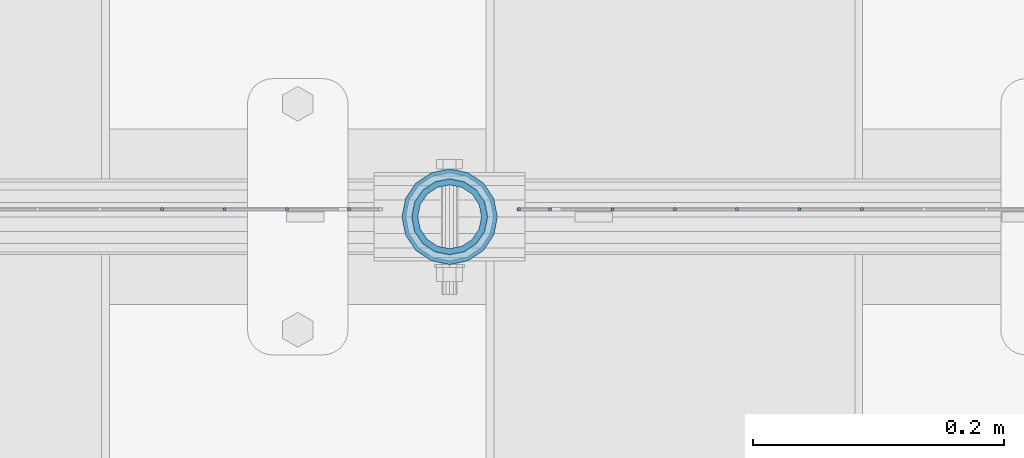
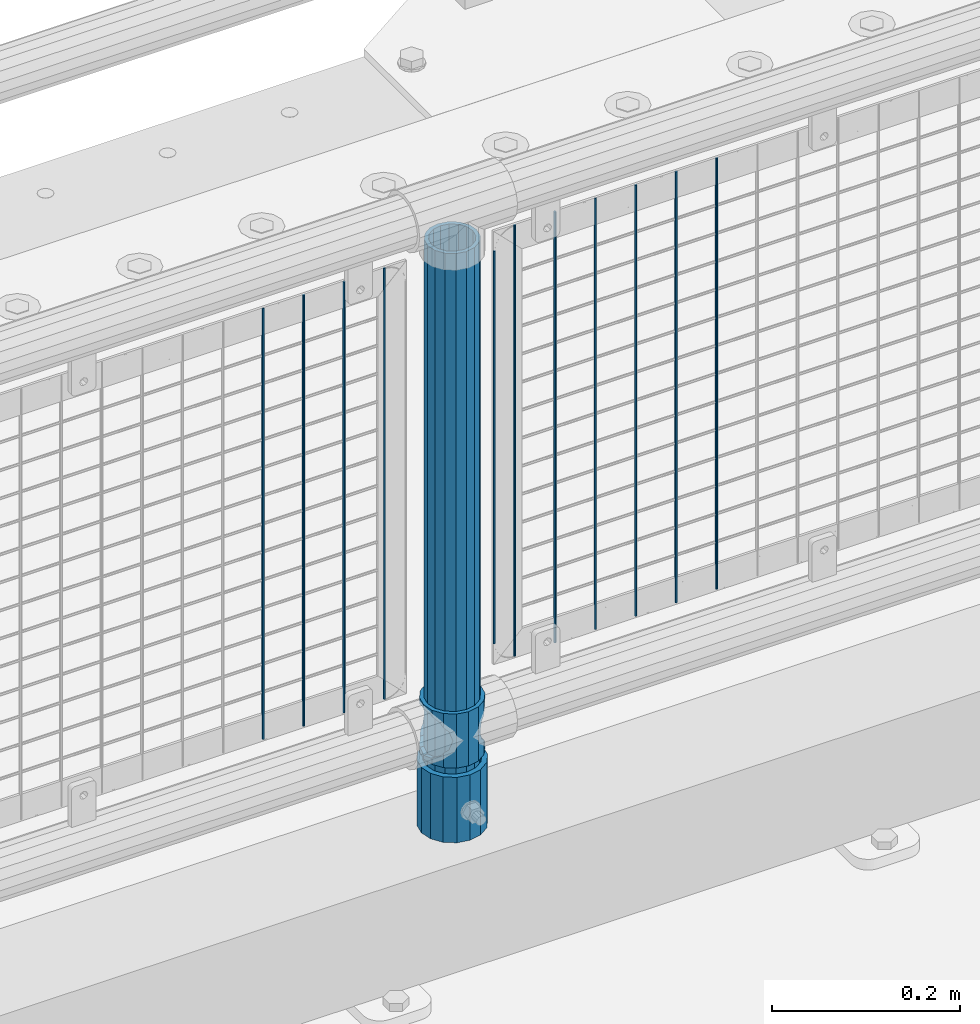
# One storey, part 70 of 208: 14 columns.
"""IFC2X3 building model written with IfcOpenShell, lengths in millimetres."""

import ifcopenshell
import ifcopenshell.guid

model = None  # the IFC model being written
_history = None  # IfcOwnerHistory: only IFC2X3 demands one
_inside = {}  # id of a spatial element -> (the spatial element, [elements in it])
_under = {}  # id of a project, library or spatial element -> (it, [spatial elements below it])
_declared = {}  # id of a project -> (the project, [libraries it declares])
_typed = {}  # id of a type object -> (the type object, [elements of that type])
_made_of = {}  # id of a material, layer set ... -> (it, [elements and type objects made of it])


def new_model(schema):
    """Start an empty IFC model of exactly this schema.

    Asked for "IFC4X3", IfcOpenShell would pick the latest addendum, in which some entities
    have other attributes; the version numbers below select the first issue.
    IFC2X3 requires an IfcOwnerHistory on every rooted entity: one is made here for all.
    """
    global model, _history
    if schema == "IFC4X3":
        model = ifcopenshell.file(schema_version=(4, 3, 0, 0))
    else:
        model = ifcopenshell.file(schema=schema)
    _inside.clear()
    _under.clear()
    _declared.clear()
    _typed.clear()
    _made_of.clear()
    _history = None
    if model.schema == "IFC2X3":
        org = make("IfcOrganization", Name="unknown")
        user = make(
            "IfcPersonAndOrganization",
            ThePerson=make("IfcPerson", FamilyName="unknown"),
            TheOrganization=org,
        )
        app = make(
            "IfcApplication",
            ApplicationDeveloper=org,
            Version="unknown",
            ApplicationFullName="unknown",
            ApplicationIdentifier="unknown",
        )
        _history = make(
            "IfcOwnerHistory",
            OwningUser=user,
            OwningApplication=app,
            ChangeAction="ADDED",
            CreationDate=0,
        )
    return model


def make(cls, **values):
    """One entity of the class cls with the attributes given. An attribute that is None is left unset."""
    return model.create_entity(
        cls, **{name: value for name, value in values.items() if value is not None}
    )


def rooted(cls, **values):
    """An entity with a GlobalId (a new one), such as an element, a storey or a relation."""
    return make(cls, GlobalId=ifcopenshell.guid.new(), OwnerHistory=_history, **values)


def si_unit(unit_type, name, prefix=None):
    """IfcSIUnit, for example si_unit("LENGTHUNIT", "METRE", prefix="MILLI")."""
    return make("IfcSIUnit", UnitType=unit_type, Prefix=prefix, Name=name)


def assignment(units):
    """IfcUnitAssignment: the units of a project."""
    return None if units is None else make("IfcUnitAssignment", Units=units)


def point(xyz):
    """IfcCartesianPoint."""
    return None if xyz is None else make("IfcCartesianPoint", Coordinates=xyz)


def direction(xyz):
    """IfcDirection."""
    return None if xyz is None else make("IfcDirection", DirectionRatios=xyz)


def frame(location, z_axis=None, x_axis=None):
    """IfcAxis2Placement3D, a coordinate frame: its origin and axes. An axis left out is left unset."""
    return make(
        "IfcAxis2Placement3D",
        Location=point(location),
        Axis=direction(z_axis),
        RefDirection=direction(x_axis),
    )


def origin_with_axes():
    """The frame at (0, 0, 0) with the z axis (0, 0, 1) and the x axis (1, 0, 0) written out."""
    return frame((0.0, 0.0, 0.0), z_axis=(0.0, 0.0, 1.0), x_axis=(1.0, 0.0, 0.0))


def place(relative_to, where):
    """IfcLocalPlacement: puts the frame where relative to a parent placement (None: the world)."""
    return make(
        "IfcLocalPlacement", PlacementRelTo=relative_to, RelativePlacement=where
    )


def context(
    kind, dimensions, precision=None, world=None, true_north=None, identifier=None
):
    """IfcGeometricRepresentationContext, for example the 3D "Model" context."""
    return make(
        "IfcGeometricRepresentationContext",
        ContextIdentifier=identifier,
        ContextType=kind,
        CoordinateSpaceDimension=dimensions,
        Precision=precision,
        WorldCoordinateSystem=world,
        TrueNorth=true_north,
    )


def subcontext(parent, identifier, kind, view, scale=None):
    """IfcGeometricRepresentationSubContext, for example "Body" below "Model"."""
    return make(
        "IfcGeometricRepresentationSubContext",
        ContextIdentifier=identifier,
        ContextType=kind,
        ParentContext=parent,
        TargetScale=scale,
        TargetView=view,
    )


def project(units=None, contexts=None):
    """IfcProject with its units and contexts."""
    return rooted(
        "IfcProject",
        Name="project",
        RepresentationContexts=contexts,
        UnitsInContext=assignment(units),
    )


def spatial(cls, under=None, at=None, **own):
    """A site, building, storey or space (cls), placed at a placement, below another one or the project."""
    s = rooted(cls, ObjectPlacement=at, **own)
    if under is not None:
        _under.setdefault(under.id(), (under, []))[1].append(s)
    return s


def faces_of(points, faces, orient=None, outer=None):
    """IfcFace entities. A face is a list of loops; a loop is a list of indices into points, from 0.

    orient and outer hold one flag for each loop. By default every Orientation is true, the
    first loop of a face is its IfcFaceOuterBound and the others are IfcFaceBound.
    """
    made = []
    for i, loops in enumerate(faces):
        bounds = []
        for j, loop in enumerate(loops):
            is_outer = j == 0 if outer is None else outer[i][j]
            bounds.append(
                make(
                    "IfcFaceOuterBound" if is_outer else "IfcFaceBound",
                    Bound=make("IfcPolyLoop", Polygon=[points[k] for k in loop]),
                    Orientation=True if orient is None else orient[i][j],
                )
            )
        made.append(make("IfcFace", Bounds=bounds))
    return made


def faceted_brep(points, faces, orient=None, outer=None, voids=None):
    """IfcFacetedBrep: a solid bounded by flat faces; with voids (closed shells), ...WithVoids."""
    shared = [point(p) for p in points]
    hull = make("IfcClosedShell", CfsFaces=faces_of(shared, faces, orient, outer))
    if voids is None:
        return make("IfcFacetedBrep", Outer=hull)
    return make(
        "IfcFacetedBrepWithVoids",
        Outer=hull,
        Voids=[
            make(cls, CfsFaces=faces_of(shared, fs, o, b)) for cls, fs, o, b in voids
        ],
    )


def shape(context_of_items, identifier, shape_type, items):
    """IfcShapeRepresentation: the items that make up one representation, for example the "Body"."""
    return make(
        "IfcShapeRepresentation",
        ContextOfItems=context_of_items,
        RepresentationIdentifier=identifier,
        RepresentationType=shape_type,
        Items=items,
    )


def material(Name=None, Category=None):
    """IfcMaterial."""
    return make("IfcMaterial", Name=Name, Category=Category)


def made_of(thing, what):
    """Note that an element or type object is made of a material, layer set ...; save() writes the relation."""
    if what is not None:
        _made_of.setdefault(what.id(), (what, []))[1].append(thing)
    return thing


def type_object(cls, material=None, **own):
    """A type object (cls), such as IfcWallType, which elements share."""
    return made_of(rooted(cls, **own), material)


def element(
    cls,
    number,
    at=None,
    inside=None,
    cuts=None,
    type_object=None,
    material=None,
    context=None,
    identifier="Body",
    shape_type=None,
    held_by="IfcProductDefinitionShape",
    body=None,
    shapes=None,
    **own,
):
    """One element of the class cls, such as IfcWall. Its Tag is "e" and its number.

    at: its placement. inside: the storey or other place that contains it. cuts: it is an
    opening in that element (IfcRelVoidsElement). A single representation is given by context,
    identifier, shape_type and body (its items); several are given by shapes. held_by: the class
    of the entity that holds the representations. save() writes the other relations.
    """
    e = rooted(cls, Tag="e%d" % number, ObjectPlacement=at, **own)
    if body is not None:
        shapes = [shape(context, identifier, shape_type, body)]
    if shapes is not None:
        e.Representation = make(held_by, Representations=shapes)
    if inside is not None:
        _inside.setdefault(inside.id(), (inside, []))[1].append(e)
    if cuts is not None:
        rooted(
            "IfcRelVoidsElement", RelatingBuildingElement=cuts, RelatedOpeningElement=e
        )
    if type_object is not None:
        _typed.setdefault(type_object.id(), (type_object, []))[1].append(e)
    return made_of(e, material)


def aggregate(whole, parts):
    """IfcRelAggregates: a whole, such as a stair, and the parts it consists of."""
    return rooted("IfcRelAggregates", RelatingObject=whole, RelatedObjects=parts)


def save(model, path):
    """Write the relations noted so far, then the file.

    IfcRelAggregates (storeys below a building ...), IfcRelContainedInSpatialStructure (elements
    in a storey), IfcRelDefinesByType, IfcRelAssociatesMaterial and IfcRelDeclares: one each for
    every whole, place, type object, material and project.
    """
    for whole, parts in _under.values():
        aggregate(whole, parts)
    for where, things in _inside.values():
        rooted(
            "IfcRelContainedInSpatialStructure",
            RelatedElements=things,
            RelatingStructure=where,
        )
    for kind, things in _typed.values():
        rooted("IfcRelDefinesByType", RelatedObjects=things, RelatingType=kind)
    for what, things in _made_of.values():
        rooted("IfcRelAssociatesMaterial", RelatedObjects=things, RelatingMaterial=what)
    for by, libraries in _declared.values():
        rooted("IfcRelDeclares", RelatingContext=by, RelatedDefinitions=libraries)
    model.write(path)


model = new_model("IFC2X3")

# Units and contexts
model_context = context("Model", 3, precision=1e-05, world=origin_with_axes())
body_context = subcontext(model_context, "Body", "Model", "MODEL_VIEW")
ifc_project = project(units=[si_unit("LENGTHUNIT", "METRE", prefix="MILLI"), si_unit("AREAUNIT", "SQUARE_METRE"), si_unit("VOLUMEUNIT", "CUBIC_METRE"), si_unit("MASSUNIT", "GRAM", prefix="KILO"), si_unit("TIMEUNIT", "SECOND"), si_unit("PLANEANGLEUNIT", "RADIAN"), si_unit("SOLIDANGLEUNIT", "STERADIAN"), si_unit("THERMODYNAMICTEMPERATUREUNIT", "DEGREE_CELSIUS"), si_unit("LUMINOUSINTENSITYUNIT", "LUMEN")], contexts=[model_context])

# Site, building, storey
site_placement = place(None, origin_with_axes())
site = spatial("IfcSite", under=ifc_project, at=site_placement, CompositionType="ELEMENT")
building_placement = place(site_placement, origin_with_axes())
building = spatial("IfcBuilding", under=site, at=building_placement, Name="Standard", CompositionType="ELEMENT")
storey_placement = place(building_placement, origin_with_axes())
storey = spatial("IfcBuildingStorey", under=building, at=storey_placement, Name="Undefined", CompositionType="ELEMENT", Elevation=0.0)

# Columns
ifc_material_1 = material()
column_type_1 = type_object("IfcColumnType", PredefinedType="NOTDEFINED")
column_1_placement = place(storey_placement, frame((-33829.0, 4664.5, 168.02), z_axis=(0.0, 1.0, 0.0), x_axis=(0.0, 0.0, 1.0)))
element("IfcColumn", 1, at=column_1_placement, inside=storey, type_object=column_type_1, material=ifc_material_1, context=body_context, shape_type="Brep", body=[
    faceted_brep([(0.0, -31.75, 0.0), (0.0, -29.3331751572332, 12.1501989775916), (85.0, -29.3331751572332, 12.1501989775916), (85.0, -31.75, 0.0), (0.0, -22.4506403026717, 22.4506403026726), (85.0, -22.4506403026717, 22.4506403026726), (0.0, -12.1501989775934, 29.3331751572332), (85.0, -12.1501989775934, 29.3331751572332), (0.0, 0.0, 31.75), (85.0, 0.0, 31.75), (0.0, 12.1501989775934, 29.3331751572332), (85.0, 12.1501989775934, 29.3331751572332), (0.0, 22.4506403026717, 22.4506403026726), (85.0, 22.4506403026717, 22.4506403026726), (0.0, 29.3331751572332, 12.1501989775916), (85.0, 29.3331751572332, 12.1501989775916), (0.0, 31.75, 0.0), (85.0, 31.75, 0.0), (0.0, 29.3331751572332, -12.1501989775916), (85.0, 29.3331751572332, -12.1501989775916), (0.0, 22.4506403026717, -22.4506403026726), (85.0, 22.4506403026717, -22.4506403026726), (0.0, 12.1501989775934, -29.3331751572332), (85.0, 12.1501989775934, -29.3331751572332), (0.0, 0.0, -31.75), (85.0, 0.0, -31.75), (0.0, -12.1501989775934, -29.3331751572332), (85.0, -12.1501989775934, -29.3331751572332), (0.0, -22.4506403026717, -22.4506403026726), (85.0, -22.4506403026717, -22.4506403026726), (0.0, -29.3331751572332, -12.1501989775916), (85.0, -29.3331751572332, -12.1501989775916), (0.0, -38.0499999999993, 0.0), (0.0, -35.1536162120537, -14.5611046014919), (85.0, -35.1536162120537, -14.5611046014919), (85.0, -38.0499999999993, 0.0), (0.0, -26.9054130241493, -26.9054130241484), (85.0, -26.9054130241493, -26.9054130241484), (0.0, -14.5611046014928, -35.1536162120547), (85.0, -14.5611046014928, -35.1536162120547), (0.0, 0.0, -38.0500000000002), (85.0, 0.0, -38.0500000000002), (0.0, 14.5611046014928, -35.1536162120547), (85.0, 14.5611046014928, -35.1536162120547), (0.0, 26.9054130241493, -26.9054130241484), (85.0, 26.9054130241493, -26.9054130241484), (0.0, 35.1536162120537, -14.5611046014919), (85.0, 35.1536162120537, -14.5611046014919), (0.0, 38.0499999999993, 0.0), (85.0, 38.0499999999993, 0.0), (0.0, 35.1536162120537, 14.5611046014919), (85.0, 35.1536162120537, 14.5611046014919), (0.0, 26.9054130241493, 26.9054130241484), (85.0, 26.9054130241493, 26.9054130241484), (0.0, 14.5611046014928, 35.1536162120547), (85.0, 14.5611046014928, 35.1536162120547), (0.0, 0.0, 38.0500000000002), (85.0, 0.0, 38.0500000000002), (0.0, -14.5611046014928, 35.1536162120547), (85.0, -14.5611046014928, 35.1536162120547), (0.0, -26.9054130241493, 26.9054130241484), (85.0, -26.9054130241493, 26.9054130241484), (0.0, -35.1536162120537, 14.5611046014919), (85.0, -35.1536162120537, 14.5611046014919)], [[[0, 1, 2, 3]], [[1, 4, 5, 2]], [[4, 6, 7, 5]], [[6, 8, 9, 7]], [[8, 10, 11, 9]], [[10, 12, 13, 11]], [[12, 14, 15, 13]], [[14, 16, 17, 15]], [[16, 18, 19, 17]], [[18, 20, 21, 19]], [[20, 22, 23, 21]], [[22, 24, 25, 23]], [[24, 26, 27, 25]], [[26, 28, 29, 27]], [[28, 30, 31, 29]], [[30, 0, 3, 31]], [[32, 33, 34, 35]], [[33, 36, 37, 34]], [[36, 38, 39, 37]], [[38, 40, 41, 39]], [[40, 42, 43, 41]], [[42, 44, 45, 43]], [[44, 46, 47, 45]], [[46, 48, 49, 47]], [[48, 50, 51, 49]], [[50, 52, 53, 51]], [[52, 54, 55, 53]], [[54, 56, 57, 55]], [[56, 58, 59, 57]], [[58, 60, 61, 59]], [[60, 62, 63, 61]], [[62, 32, 35, 63]], [[37, 39, 41, 43, 45, 47, 49, 51, 53, 55, 57, 59, 61, 63, 35, 34], [5, 7, 9, 11, 13, 15, 17, 19, 21, 23, 25, 27, 29, 31, 3, 2]], [[62, 60, 58, 56, 54, 52, 50, 48, 46, 44, 42, 40, 38, 36, 33, 32], [30, 28, 26, 24, 22, 20, 18, 16, 14, 12, 10, 8, 6, 4, 1, 0]]]),
])
ifc_material_2 = material(Name="Misc_Undefined")
column_type_2 = type_object("IfcColumnType", PredefinedType="NOTDEFINED")
column_2_placement = place(storey_placement, frame((-33829.0, 4664.5, 263.02), z_axis=(-1.0, 0.0, 0.0), x_axis=(0.0, 0.0, 1.0)))
element("IfcColumn", 2, at=column_2_placement, inside=storey, type_object=column_type_2, material=ifc_material_2, context=body_context, shape_type="Brep", body=[
    faceted_brep([(63.1897438117172, 11.6144421722802, -32.8397438117245), (63.1897438117172, 11.6144421722802, -28.0397438117143), (56.6106908090114, 21.4606908090118, -21.4606908090136), (56.6106908090114, 21.4606908090118, -27.1226768591077), (61.962379517676, 13.4513226476329, -32.4743655677739), (46.7644421722801, 28.0397438117179, -11.6144421722784), (46.7644421722801, 28.0397438117179, -20.0882031229921), (51.531042408003, 24.8548033587067, -24.8548033587067), (35.1500000000015, 30.35, 0.0), (35.1499999999996, 30.3500000000004, -16.6306603983685), (23.5355578277192, 28.0397438117179, -11.6144421722784), (23.5355578277192, 28.0397438117179, -20.0882031229921), (18.7689575919962, 24.8548033587067, -24.8548033587067), (13.6893091909879, 21.4606908090118, -21.4606908090136), (13.6893091909879, 21.4606908090118, -27.1226768591077), (8.33762048232325, 13.4513226476329, -32.4743655677739), (7.11025618828211, 11.6144421722802, -28.0397438117143), (7.11025618828211, 11.6144421722802, -32.8397438117245), (4.79999999999961, 0.0, -30.3499999999985), (4.79999999999961, 0.0, -35.1500000000015), (7.11025618828205, -11.6144421722802, -28.0397438117143), (7.11025618828205, -11.6144421722802, -32.8397438117245), (13.6893091909879, -21.4606908090118, -21.4606908090136), (13.6893091909879, -21.4606908090118, -27.1226768591005), (8.33762048232325, -13.4513226476329, -32.4743655677739), (23.5355578277191, -28.0397438117179, -11.6144421722784), (23.5355578277191, -28.0397438117179, -20.0882031229921), (18.7689575919962, -24.8548033587067, -24.8548033587067), (35.1500000000015, -30.35, 0.0), (35.1499999999996, -30.3500000000004, -16.6306603983685), (46.7644421722801, -28.0397438117179, -11.6144421722784), (46.7644421722801, -28.0397438117179, -20.0882031229921), (51.531042408003, -24.8548033587067, -24.8548033587067), (56.6106908090114, -21.4606908090118, -21.4606908090136), (56.6106908090114, -21.4606908090118, -27.1226768591005), (61.962379517675, -13.4513226476329, -32.4743655677739), (63.1897438117172, -11.6144421722802, -28.0397438117143), (63.1897438117172, -11.6144421722802, -32.8397438117245), (65.4999999999997, 0.0, -30.3499999999985), (65.4999999999997, 0.0, -35.1500000000015), (0.0, -28.0397438117179, -11.6144421722784), (0.0, -30.3500000000004, 0.0), (0.0, -21.4606908090118, -21.4606908090136), (0.0, -11.6144421722802, -28.0397438117143), (0.0, 0.0, -30.3499999999985), (0.0, 11.6144421722802, -28.0397438117143), (0.0, 21.4606908090118, -21.4606908090136), (0.0, 28.0397438117179, -11.6144421722784), (0.0, 30.3500000000004, 0.0), (0.0, 28.0397438117179, 11.6144421722784), (23.5355578277192, 28.0397438117179, 11.6144421722784), (0.0, 21.4606908090118, 21.4606908090136), (13.6893091909879, 21.4606908090118, 21.4606908090136), (0.0, 11.6144421722802, 28.0397438117143), (7.11025618828211, 11.6144421722802, 28.0397438117143), (0.0, 0.0, 30.3499999999985), (4.79999999999961, 0.0, 30.3499999999985), (0.0, -11.6144421722802, 28.0397438117143), (7.11025618828205, -11.6144421722802, 28.0397438117143), (0.0, -21.4606908090118, 21.4606908090136), (13.6893091909879, -21.4606908090118, 21.4606908090136), (0.0, -28.0397438117179, 11.6144421722784), (23.5355578277191, -28.0397438117179, 11.6144421722784), (0.0, -32.4743655677721, 13.4513226476338), (0.0, -35.1499999999996, 0.0), (70.2999999999993, -35.1499999999996, 0.0), (70.2999999999993, -32.4743655677721, 13.4513226476338), (0.0, 13.4513226476329, -32.4743655677739), (0.0, 24.8548033587067, -24.8548033587067), (0.0, 0.0, -35.1499999999996), (0.0, -13.4513226476329, -32.4743655677739), (0.0, -24.8548033587067, -24.8548033587067), (0.0, -24.8548033587067, 24.8548033587067), (0.0, -13.4513226476329, 32.4743655677739), (0.0, 0.0, 35.1499999999996), (0.0, 13.4513226476329, 32.4743655677739), (0.0, 24.8548033587067, 24.8548033587067), (0.0, 32.4743655677721, 13.4513226476338), (0.0, 35.1499999999996, 0.0), (0.0, 32.4743655677721, -13.4513226476338), (0.0, -32.4743655677721, -13.4513226476338), (70.2999999999993, 32.4743655677721, 13.4513226476338), (70.2999999999993, 35.1499999999996, 0.0), (70.2999999999993, 32.4743655677721, -13.4513226476338), (70.2999999999993, 24.8548033587067, -24.8548033587067), (70.2999999999993, 13.4513226476329, -32.4743655677739), (70.2999999999993, 0.0, -35.1500000000015), (70.2999999999993, -13.4513226476329, -32.4743655677739), (70.2999999999993, -24.8548033587067, -24.8548033587067), (70.2999999999993, -32.4743655677721, -13.4513226476338), (70.2999999999993, 28.0397438117179, 11.6144421722784), (70.2999999999993, 21.4606908090118, 21.4606908090136), (56.6106908090114, 21.4606908090118, 21.4606908090136), (46.7644421722801, 28.0397438117179, 11.6144421722784), (70.2999999999993, 11.6144421722802, 28.0397438117143), (63.1897438117172, 11.6144421722802, 28.0397438117143), (70.2999999999993, 0.0, 30.3499999999985), (65.4999999999997, 0.0, 30.3499999999985), (70.2999999999993, -11.6144421722802, 28.0397438117143), (63.1897438117172, -11.6144421722802, 28.0397438117143), (70.2999999999993, -21.4606908090118, 21.4606908090136), (56.6106908090114, -21.4606908090118, 21.4606908090136), (70.2999999999993, -28.0397438117179, 11.6144421722784), (46.7644421722801, -28.0397438117179, 11.6144421722784), (70.2999999999993, -11.6144421722802, -28.0397438117143), (70.2999999999993, 0.0, -30.3499999999985), (70.2999999999993, -21.4606908090118, -21.4606908090136), (70.2999999999993, -28.0397438117179, -11.6144421722784), (70.2999999999993, -30.3500000000004, 0.0), (70.2999999999993, 24.8548033587067, 24.8548033587067), (70.2999999999993, 13.4513226476329, 32.4743655677739), (70.2999999999993, 0.0, 35.1500000000015), (70.2999999999993, -13.4513226476329, 32.4743655677739), (70.2999999999993, -24.8548033587067, 24.8548033587067), (70.2999999999993, 30.3500000000004, 0.0), (70.2999999999993, 28.0397438117179, -11.6144421722784), (70.2999999999993, 21.4606908090118, -21.4606908090136), (70.2999999999993, 11.6144421722802, -28.0397438117143), (61.9623795176756, 13.4513226476329, 32.4743655677739), (51.531042408003, 24.8548033587067, 24.8548033587067), (56.6106908090114, 21.4606908090118, 27.1226768591005), (65.4999999999997, 0.0, 35.1500000000015), (63.1897438117172, 11.6144421722802, 32.8397438117172), (63.1897438117172, -11.6144421722802, 32.8397438117245), (61.962379517675, -13.4513226476329, 32.4743655677739), (56.6106908090114, -21.4606908090118, 27.1226768591077), (51.531042408003, -24.8548033587067, 24.8548033587067), (18.7689575919962, -24.8548033587067, 24.8548033587067), (46.7644421722801, -28.0397438117179, 20.0882031229776), (35.1499999999996, -30.3500000000004, 16.6306603983612), (23.5355578277191, -28.0397438117179, 20.0882031229776), (8.3376204823237, -13.4513226476329, 32.4743655677739), (13.6893091909879, -21.4606908090118, 27.1226768591077), (4.79999999999961, 0.0, 35.1500000000015), (7.11025618828205, -11.6144421722802, 32.8397438117245), (7.11025618828211, 11.6144421722802, 32.8397438117172), (8.3376204823237, 13.4513226476329, 32.4743655677739), (13.6893091909879, 21.4606908090118, 27.1226768591005), (18.7689575919962, 24.8548033587067, 24.8548033587067), (23.5355578277192, 28.0397438117179, 20.0882031229921), (35.1499999999996, 30.3500000000004, 16.6306603983685), (46.7644421722801, 28.0397438117179, 20.0882031229921)], [[[0, 1, 2, 3, 4]], [[3, 2, 5, 6, 7]], [[6, 5, 8, 9]], [[9, 8, 10, 11]], [[12, 11, 10, 13, 14]], [[15, 14, 13, 16, 17]], [[17, 16, 18, 19]], [[19, 18, 20, 21]], [[21, 20, 22, 23, 24]], [[23, 22, 25, 26, 27]], [[26, 25, 28, 29]], [[29, 28, 30, 31]], [[32, 31, 30, 33, 34]], [[35, 34, 33, 36, 37]], [[37, 36, 38, 39]], [[39, 38, 1, 0]], [[40, 41, 28, 25]], [[42, 40, 25, 22]], [[43, 42, 22, 20]], [[44, 43, 20, 18]], [[45, 44, 18, 16]], [[46, 45, 16, 13]], [[47, 46, 13, 10]], [[48, 47, 10, 8]], [[49, 48, 8, 50]], [[51, 49, 50, 52]], [[53, 51, 52, 54]], [[55, 53, 54, 56]], [[57, 55, 56, 58]], [[59, 57, 58, 60]], [[61, 59, 60, 62]], [[41, 61, 62, 28]], [[63, 64, 65, 66]], [[67, 68, 12, 14, 15]], [[69, 67, 15, 17, 19]], [[24, 70, 69, 19, 21]], [[27, 71, 70, 24, 23]], [[63, 72, 73, 74, 75, 76, 77, 78, 79, 68, 67, 69, 70, 71, 80, 64], [40, 42, 43, 44, 45, 46, 47, 48, 49, 51, 53, 55, 57, 59, 61, 41]], [[78, 77, 81, 82]], [[79, 78, 82, 83]], [[9, 11, 12, 68, 79, 83, 84, 7, 6]], [[7, 84, 85, 4, 3]], [[4, 85, 86, 39, 0]], [[87, 88, 32, 34, 35]], [[86, 87, 35, 37, 39]], [[88, 89, 80, 71, 27, 26, 29, 31, 32]], [[64, 80, 89, 65]], [[90, 91, 92, 93]], [[91, 94, 95, 92]], [[94, 96, 97, 95]], [[96, 98, 99, 97]], [[98, 100, 101, 99]], [[100, 102, 103, 101]], [[104, 105, 38, 36]], [[106, 104, 36, 33]], [[107, 106, 33, 30]], [[108, 107, 30, 28]], [[102, 108, 28, 103]], [[88, 87, 86, 85, 84, 83, 82, 81, 109, 110, 111, 112, 113, 66, 65, 89], [100, 98, 96, 94, 91, 90, 114, 115, 116, 117, 105, 104, 106, 107, 108, 102]], [[118, 110, 109, 119, 120]], [[121, 111, 110, 118, 122]], [[112, 111, 121, 123, 124]], [[113, 112, 124, 125, 126]], [[127, 72, 63, 66, 113, 126, 128, 129, 130]], [[131, 73, 72, 127, 132]], [[133, 74, 73, 131, 134]], [[75, 74, 133, 135, 136]], [[76, 75, 136, 137, 138]], [[119, 109, 81, 77, 76, 138, 139, 140, 141]], [[92, 120, 119, 141, 93]], [[95, 122, 118, 120, 92]], [[97, 121, 122, 95]], [[99, 123, 121, 97]], [[101, 125, 124, 123, 99]], [[103, 128, 126, 125, 101]], [[28, 129, 128, 103]], [[62, 130, 129, 28]], [[60, 132, 127, 130, 62]], [[58, 134, 131, 132, 60]], [[56, 133, 134, 58]], [[54, 135, 133, 56]], [[52, 137, 136, 135, 54]], [[50, 139, 138, 137, 52]], [[8, 140, 139, 50]], [[93, 141, 140, 8]], [[114, 90, 93, 8]], [[115, 114, 8, 5]], [[116, 115, 5, 2]], [[117, 116, 2, 1]], [[105, 117, 1, 38]]]),
])
column_type_3 = type_object("IfcColumnType", PredefinedType="NOTDEFINED")
column_3_placement = place(storey_placement, frame((-33829.0, 4664.5, 168.02), z_axis=(-1.0, 0.0, 0.0), x_axis=(0.0, 0.0, 1.0)))
element("IfcColumn", 3, at=column_3_placement, inside=storey, type_object=column_type_3, material=ifc_material_1, context=body_context, shape_type="Brep", body=[
    faceted_brep([(0.0, -25.3500000000004, 0.0), (0.0, -23.4203461491616, 9.70102501045403), (760.0, -23.4203461491616, 9.70102501045403), (760.0, -25.3500000000004, 0.0), (0.0, -17.9251569030794, 17.9251569030785), (760.0, -17.9251569030794, 17.9251569030785), (0.0, -9.70102501045494, 23.4203461491597), (760.0, -9.70102501045494, 23.4203461491597), (0.0, 0.0, 25.3499999999985), (760.0, 0.0, 25.3499999999985), (0.0, 9.70102501045494, 23.4203461491597), (760.0, 9.70102501045494, 23.4203461491597), (0.0, 17.9251569030794, 17.9251569030785), (760.0, 17.9251569030794, 17.9251569030785), (0.0, 23.4203461491616, 9.70102501045403), (760.0, 23.4203461491616, 9.70102501045403), (0.0, 25.3500000000004, 0.0), (760.0, 25.3500000000004, 0.0), (0.0, 23.4203461491616, -9.70102501045403), (760.0, 23.4203461491616, -9.70102501045403), (0.0, 17.9251569030794, -17.9251569030785), (760.0, 17.9251569030794, -17.9251569030785), (0.0, 9.70102501045494, -23.4203461491597), (760.0, 9.70102501045494, -23.4203461491597), (0.0, 0.0, -25.3499999999985), (760.0, 0.0, -25.3499999999985), (0.0, -9.70102501045494, -23.4203461491597), (760.0, -9.70102501045494, -23.4203461491597), (0.0, -17.9251569030794, -17.9251569030785), (760.0, -17.9251569030794, -17.9251569030785), (0.0, -23.4203461491616, -9.70102501045403), (760.0, -23.4203461491616, -9.70102501045403), (0.0, -30.1499999999996, 0.0), (0.0, -27.8549679052148, -11.5379054858058), (760.0, -27.8549679052148, -11.5379054858058), (760.0, -30.1499999999996, 0.0), (0.0, -21.3192694527743, -21.3192694527752), (760.0, -21.3192694527743, -21.3192694527752), (0.0, -11.5379054858076, -27.8549679052157), (760.0, -11.5379054858076, -27.8549679052157), (0.0, 0.0, -30.1500000000015), (760.0, 0.0, -30.1500000000015), (0.0, 11.5379054858076, -27.8549679052157), (760.0, 11.5379054858076, -27.8549679052157), (0.0, 21.3192694527743, -21.3192694527752), (760.0, 21.3192694527743, -21.3192694527752), (0.0, 27.8549679052157, -11.5379054858058), (760.0, 27.8549679052157, -11.5379054858058), (0.0, 30.1499999999996, 0.0), (760.0, 30.1499999999996, 0.0), (0.0, 27.8549679052157, 11.5379054858058), (760.0, 27.8549679052157, 11.5379054858058), (0.0, 21.3192694527743, 21.3192694527752), (760.0, 21.3192694527743, 21.3192694527752), (0.0, 11.5379054858076, 27.8549679052157), (760.0, 11.5379054858076, 27.8549679052157), (0.0, 0.0, 30.1500000000015), (760.0, 0.0, 30.1500000000015), (0.0, -11.5379054858076, 27.8549679052157), (760.0, -11.5379054858076, 27.8549679052157), (0.0, -21.3192694527743, 21.3192694527752), (760.0, -21.3192694527743, 21.3192694527752), (0.0, -27.8549679052157, 11.5379054858058), (760.0, -27.8549679052157, 11.5379054858058)], [[[0, 1, 2, 3]], [[1, 4, 5, 2]], [[4, 6, 7, 5]], [[6, 8, 9, 7]], [[8, 10, 11, 9]], [[10, 12, 13, 11]], [[12, 14, 15, 13]], [[14, 16, 17, 15]], [[16, 18, 19, 17]], [[18, 20, 21, 19]], [[20, 22, 23, 21]], [[22, 24, 25, 23]], [[24, 26, 27, 25]], [[26, 28, 29, 27]], [[28, 30, 31, 29]], [[30, 0, 3, 31]], [[32, 33, 34, 35]], [[33, 36, 37, 34]], [[36, 38, 39, 37]], [[38, 40, 41, 39]], [[40, 42, 43, 41]], [[42, 44, 45, 43]], [[44, 46, 47, 45]], [[46, 48, 49, 47]], [[48, 50, 51, 49]], [[50, 52, 53, 51]], [[52, 54, 55, 53]], [[54, 56, 57, 55]], [[56, 58, 59, 57]], [[58, 60, 61, 59]], [[60, 62, 63, 61]], [[62, 32, 35, 63]], [[37, 39, 41, 43, 45, 47, 49, 51, 53, 55, 57, 59, 61, 63, 35, 34], [5, 7, 9, 11, 13, 15, 17, 19, 21, 23, 25, 27, 29, 31, 3, 2]], [[62, 60, 58, 56, 54, 52, 50, 48, 46, 44, 42, 40, 38, 36, 33, 32], [30, 28, 26, 24, 22, 20, 18, 16, 14, 12, 10, 8, 6, 4, 1, 0]]]),
])
column_type_4 = type_object("IfcColumnType", Name="D3", PredefinedType="NOTDEFINED")
for number, where, z_axis, x_axis in (
    (4, (-33500.725, 4670.5, 353.020000000003), (-1.0, 0.0, 0.0), (0.0, 0.0, 1.0)),
    (5, (-33550.38, 4670.5, 353.020000000003), (-1.0, 0.0, 0.0), (0.0, 0.0, 1.0)),
    (6, (-33600.035, 4670.5, 353.020000000003), (-1.0, 0.0, 0.0), (0.0, 0.0, 1.0)),
    (7, (-33649.6896551724, 4670.5, 353.020000000003), (-1.0, 0.0, 0.0), (0.0, 0.0, 1.0)),
    (8, (-33699.3448275862, 4670.5, 353.020000000003), (-0.999999999962839, 0.0, 8.62099999968473e-06), (8.62099999949798e-06, 0.0, 0.999999999962839)),
):
    element("IfcColumn", number, at=place(storey_placement, frame(where, z_axis=z_axis, x_axis=x_axis)), inside=storey, type_object=column_type_4, material=ifc_material_2, ObjectType="D3", context=body_context, shape_type="Brep", body=[
        faceted_brep([(0.0, -1.49999999999909, 3.63797880709171e-12), (-7.27595761418343e-12, -0.749999999999091, -1.29903810567669), (560.0, -0.75, -1.29903810567703), (560.0, -1.5, 0.0), (-3.63797880709171e-12, 0.750000000000909, -1.29903810567669), (560.0, 0.75, -1.29903810567703), (0.0, 1.50000000000182, 3.63797880709171e-12), (560.0, 1.5, 0.0), (-3.63797880709171e-12, 0.750000000000909, 1.29903810567669), (560.0, 0.75, 1.29903810567703), (-7.27595761418343e-12, -0.749999999999091, 1.29903810567669), (560.0, -0.75, 1.29903810567703)], [[[0, 1, 2, 3]], [[1, 4, 5, 2]], [[4, 6, 7, 5]], [[6, 8, 9, 7]], [[8, 10, 11, 9]], [[10, 0, 3, 11]], [[5, 7, 9, 11, 3, 2]], [[10, 8, 6, 4, 1, 0]]]),
    ])
column_4_placement = place(storey_placement, frame((-33774.0, 4670.5, 378.020000000003), z_axis=(-1.0, 0.0, 0.0), x_axis=(0.0, 0.0, 1.0)))
element("IfcColumn", 9, at=column_4_placement, inside=storey, type_object=column_type_4, material=ifc_material_2, ObjectType="D3", context=body_context, shape_type="Brep", body=[
    faceted_brep([(0.0, -1.49999999999909, 3.63797880709171e-12), (-7.27595761418343e-12, -0.749999999999091, -1.29903810567669), (510.0, -0.75, -1.29903810567703), (510.0, -1.5, 0.0), (-3.63797880709171e-12, 0.750000000000909, -1.29903810567669), (510.0, 0.75, -1.29903810567703), (0.0, 1.50000000000182, 3.63797880709171e-12), (510.0, 1.5, 0.0), (-3.63797880709171e-12, 0.750000000000909, 1.29903810567669), (510.0, 0.75, 1.29903810567703), (-7.27595761418343e-12, -0.749999999999091, 1.29903810567669), (510.0, -0.75, 1.29903810567703)], [[[0, 1, 2, 3]], [[1, 4, 5, 2]], [[4, 6, 7, 5]], [[6, 8, 9, 7]], [[8, 10, 11, 9]], [[10, 0, 3, 11]], [[5, 7, 9, 11, 3, 2]], [[10, 8, 6, 4, 1, 0]]]),
])
for number, where, z_axis, x_axis in (
    (10, (-33749.0, 4670.5, 353.020000000003), (-1.0, 0.0, 0.0), (0.0, 0.0, 1.0)),
    (11, (-33909.005, 4670.50000000001, 353.020000000002), (-1.0, 0.0, 0.0), (0.0, 0.0, 1.0)),
    (12, (-33958.66, 4670.50000000001, 353.020000000002), (-1.0, 0.0, 0.0), (0.0, 0.0, 1.0)),
    (13, (-34008.315, 4670.50000000001, 353.020000000002), (-1.0, 0.0, 0.0), (0.0, 0.0, 1.0)),
    (14, (-34057.97, 4670.50000000001, 353.020000000002), (-1.0, 0.0, 0.0), (0.0, 0.0, 1.0)),
):
    element("IfcColumn", number, at=place(storey_placement, frame(where, z_axis=z_axis, x_axis=x_axis)), inside=storey, type_object=column_type_4, material=ifc_material_2, ObjectType="D3", context=body_context, shape_type="Brep", body=[
        faceted_brep([(0.0, -1.49999999999909, 3.63797880709171e-12), (-7.27595761418343e-12, -0.749999999999091, -1.29903810567669), (560.0, -0.75, -1.29903810567703), (560.0, -1.5, 0.0), (-3.63797880709171e-12, 0.750000000000909, -1.29903810567669), (560.0, 0.75, -1.29903810567703), (0.0, 1.50000000000182, 3.63797880709171e-12), (560.0, 1.5, 0.0), (-3.63797880709171e-12, 0.750000000000909, 1.29903810567669), (560.0, 0.75, 1.29903810567703), (-7.27595761418343e-12, -0.749999999999091, 1.29903810567669), (560.0, -0.75, 1.29903810567703)], [[[0, 1, 2, 3]], [[1, 4, 5, 2]], [[4, 6, 7, 5]], [[6, 8, 9, 7]], [[8, 10, 11, 9]], [[10, 0, 3, 11]], [[5, 7, 9, 11, 3, 2]], [[10, 8, 6, 4, 1, 0]]]),
    ])

save(model, "model.ifc")
